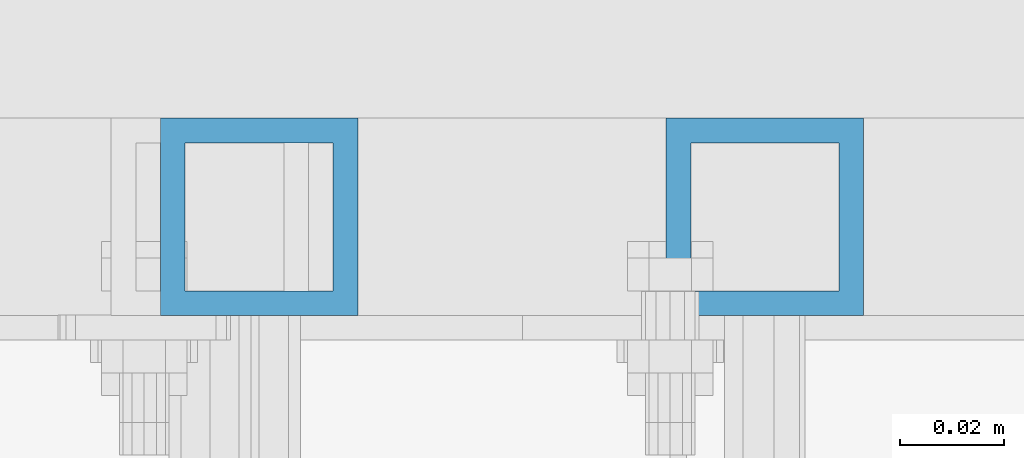
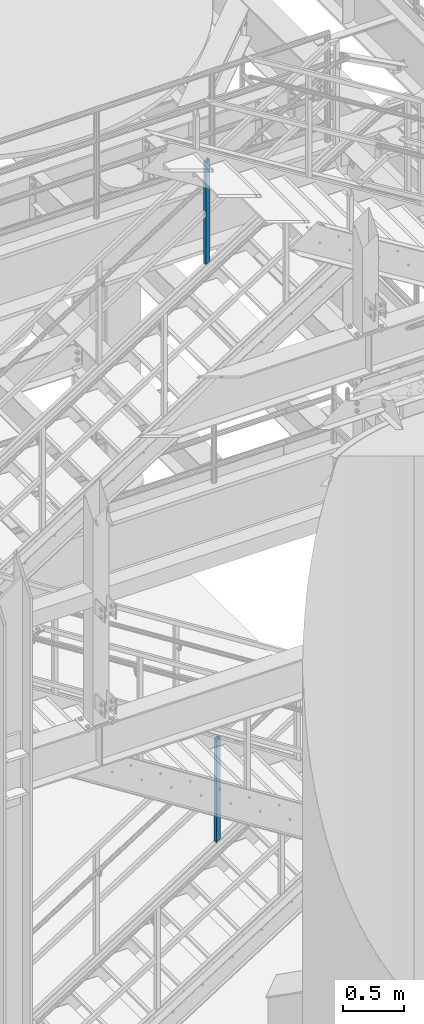
# One storey, part 638 of 1876: 2 columns, 2 elements without a shape of their own.
"""IFC2X3 building model written with IfcOpenShell, lengths in millimetres."""

from ifc_helpers import new_model, si_unit, frame, origin_with_axes, place, context, subcontext, project, spatial, faceted_brep, material, type_object, element, aggregate, save


model = new_model("IFC2X3")

# Units and contexts
model_context = context("Model", 3, precision=1e-05, world=origin_with_axes())
body_context = subcontext(model_context, "Body", "Model", "MODEL_VIEW")
ifc_project = project(units=[si_unit("LENGTHUNIT", "METRE", prefix="MILLI"), si_unit("AREAUNIT", "SQUARE_METRE"), si_unit("VOLUMEUNIT", "CUBIC_METRE"), si_unit("MASSUNIT", "GRAM", prefix="KILO"), si_unit("TIMEUNIT", "SECOND"), si_unit("PLANEANGLEUNIT", "RADIAN"), si_unit("SOLIDANGLEUNIT", "STERADIAN"), si_unit("THERMODYNAMICTEMPERATUREUNIT", "DEGREE_CELSIUS"), si_unit("LUMINOUSINTENSITYUNIT", "LUMEN")], contexts=[model_context])

# Site, building, storey
site_placement = place(None, origin_with_axes())
site = spatial("IfcSite", under=ifc_project, at=site_placement, CompositionType="ELEMENT")
building_placement = place(site_placement, origin_with_axes())
building = spatial("IfcBuilding", under=site, at=building_placement, Name="Undefined", CompositionType="ELEMENT")
storey_placement = place(building_placement, origin_with_axes())
storey = spatial("IfcBuildingStorey", under=building, at=storey_placement, Name="Undefined", CompositionType="ELEMENT", Elevation=0.0)

# Assembly, column
assembly_1_placement = place(storey_placement, origin_with_axes())
assembly_1 = element("IfcElementAssembly", 1, at=assembly_1_placement, inside=storey, Name="RAIL", AssemblyPlace="NOTDEFINED", PredefinedType="RIGID_FRAME")
ifc_material = material()
column_type = type_object("IfcColumnType", Name="HSS1-1/2X1-1/2X3/16", PredefinedType="NOTDEFINED")
column_1_placement = place(assembly_1_placement, frame((5025.23125001297, -4781.55000114554, 1655.06339987764), z_axis=(-1.0, 0.0, 0.0), x_axis=(0.0, 0.0, 1.0)))
column_1 = element("IfcColumn", 2, at=column_1_placement, type_object=column_type, material=ifc_material, Name="POST", ObjectType="HSS1-1/2X1-1/2X3/16", context=body_context, shape_type="Brep", body=[
    faceted_brep([(1026.24509902744, -19.0500000000002, -19.0499992349996), (1026.24509902744, 19.0499992349996, -19.0499992349996), (1002.07429278916, 19.0499992349996, 19.0499992349996), (1002.07429278916, -19.0499992349996, 19.0499992349996), (1023.22374824753, -14.2874994260001, -14.2874994260001), (1005.09564356916, -14.2874994260001, 14.2874994260001), (1005.09564356916, 14.2874994260001, 14.2874994260001), (1023.22374824753, 14.2874994260001, -14.2874994260001), (-12.0854031191318, 19.0499992349996, 19.0499992349996), (-12.0854031191318, -19.0499992349996, 19.0499992349996), (12.0854031191295, -19.0499992349996, -19.0499992349996), (12.0854031191295, 19.0499992349996, -19.0499992349996), (-9.06405233919031, 14.2874994260001, 14.2874994260001), (-9.06405233919031, -14.2874994260001, 14.2874994260001), (9.06405233918804, -14.2874994260001, -14.2874994260001), (9.06405233918804, 14.2874994260001, -14.2874994260001)], [[[0, 1, 2, 3], [4, 5, 6, 7]], [[8, 9, 3, 2]], [[9, 10, 0, 3]], [[10, 11, 1, 0]], [[11, 8, 2, 1]], [[10, 9, 8, 11], [12, 13, 14, 15]], [[15, 14, 4, 7]], [[12, 15, 7, 6]], [[13, 12, 6, 5]], [[14, 13, 5, 4]]]),
])
aggregate(assembly_1, [column_1])

assembly_2_placement = place(storey_placement, origin_with_axes())
assembly_2 = element("IfcElementAssembly", 3, at=assembly_2_placement, inside=storey, Name="RAIL", AssemblyPlace="NOTDEFINED", PredefinedType="RIGID_FRAME")
column_2_placement = place(assembly_2_placement, frame((4927.59999403856, -4781.55000114554, 7449.50458381632), z_axis=(-1.0, 0.0, 0.0), x_axis=(0.0, 0.0, 1.0)))
column_2 = element("IfcColumn", 4, at=column_2_placement, type_object=column_type, material=ifc_material, Name="POST", ObjectType="HSS1-1/2X1-1/2X3/16", context=body_context, shape_type="Brep", body=[
    faceted_brep([(1026.23571825648, -19.0500000000002, -19.0499992349996), (1026.23571825648, 19.0499992349996, -19.0499992349996), (1001.99026470106, 19.0499992349996, 19.0499992349996), (1001.99026470106, -19.0499992349996, 19.0499992349996), (1023.20503656197, -14.2874994260001, -14.2874994260001), (1005.02094639574, -14.2874994260001, 14.2874994260001), (1005.02094639574, 14.2874994260001, 14.2874994260001), (1023.20503656197, 14.2874994260001, -14.2874994260001), (-12.1227267776903, 19.0499992349996, 19.0499992349996), (-12.1227267776903, -19.0499992349996, 19.0499992349996), (12.1227267777067, -19.0499992349996, -19.0499992349996), (12.1227267777067, 19.0499992349996, -19.0499992349996), (-9.09204508310631, 14.2874994260001, 14.2874994260001), (-9.09204508310631, -14.2874994260001, 14.2874994260001), (9.09204508312268, -14.2874994260001, -14.2874994260001), (9.09204508312268, 14.2874994260001, -14.2874994260001)], [[[0, 1, 2, 3], [4, 5, 6, 7]], [[8, 9, 3, 2]], [[9, 10, 0, 3]], [[10, 11, 1, 0]], [[11, 8, 2, 1]], [[10, 9, 8, 11], [12, 13, 14, 15]], [[15, 14, 4, 7]], [[12, 15, 7, 6]], [[13, 12, 6, 5]], [[14, 13, 5, 4]]]),
])
aggregate(assembly_2, [column_2])

save(model, "model.ifc")
